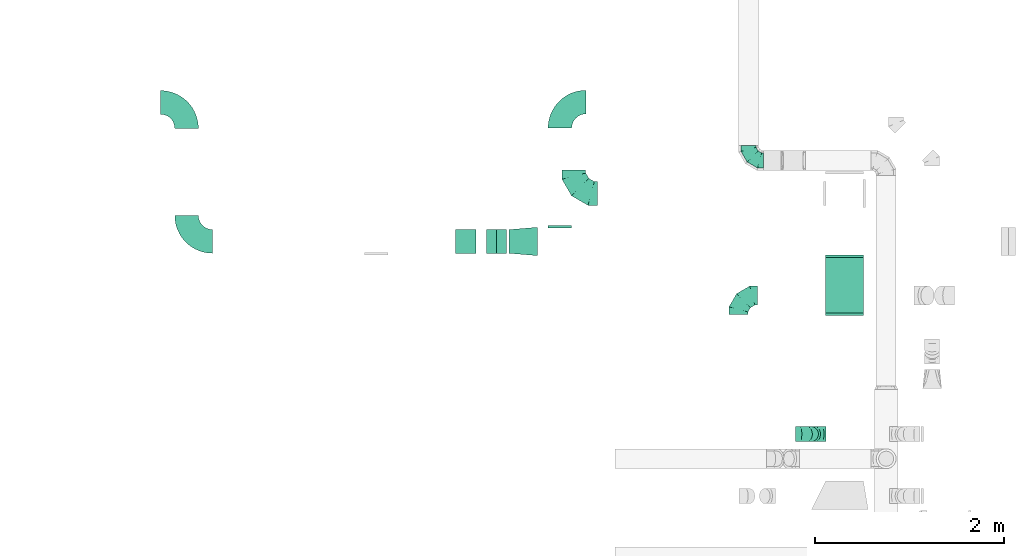
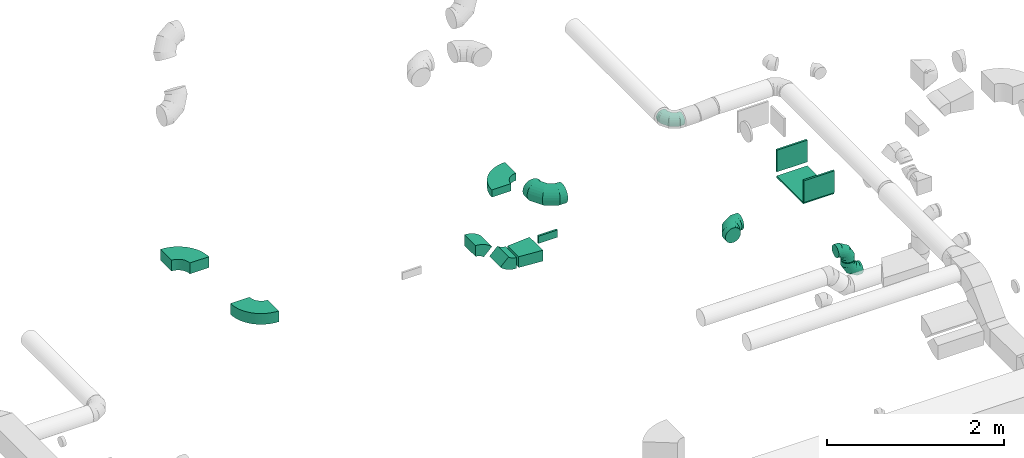
# One storey, part 35 of 62: 15 flow fittings.
"""IFC2X3 building model written with IfcOpenShell, lengths in millimetres."""

from ifc_helpers import new_model, entity, si_unit, converted_unit, derived_unit, direction, frame, frame_2d, origin, origin_2d_with_axis, place, context, subcontext, project, spatial, polyline, circle_curve, parameter, trimmed, segment, composite_curve, rectangle, outline, extrude, faceted_brep, source, transform, mapped, material, type_object, type_shapes, element, save


model = new_model("IFC2X3")

# Units and contexts
model_context = context("Model", 3, precision=0.01, world=origin(), true_north=direction((6.12303176911189e-17, 1.0)))
body_context = subcontext(model_context, "Body", "Model", "MODEL_VIEW")
ifc_project = project(units=[si_unit("LENGTHUNIT", "METRE", prefix="MILLI"), si_unit("AREAUNIT", "SQUARE_METRE"), si_unit("VOLUMEUNIT", "CUBIC_METRE"), converted_unit("PLANEANGLEUNIT", "DEGREE", entity("IfcRatioMeasure", 0.0174532925199433), si_unit("PLANEANGLEUNIT", "RADIAN"), dimensions=[0, 0, 0, 0, 0, 0, 0]), si_unit("MASSUNIT", "GRAM", prefix="KILO"), derived_unit("MASSDENSITYUNIT", [(si_unit("MASSUNIT", "GRAM", prefix="KILO"), 1), (si_unit("LENGTHUNIT", "METRE"), -3)]), derived_unit("MOMENTOFINERTIAUNIT", [(si_unit("LENGTHUNIT", "METRE"), 4)]), si_unit("TIMEUNIT", "SECOND"), si_unit("FREQUENCYUNIT", "HERTZ"), si_unit("THERMODYNAMICTEMPERATUREUNIT", "DEGREE_CELSIUS"), derived_unit("THERMALTRANSMITTANCEUNIT", [(si_unit("MASSUNIT", "GRAM", prefix="KILO"), 1), (si_unit("THERMODYNAMICTEMPERATUREUNIT", "KELVIN"), -1), (si_unit("TIMEUNIT", "SECOND"), -3)]), derived_unit("VOLUMETRICFLOWRATEUNIT", [(si_unit("LENGTHUNIT", "METRE"), 3), (si_unit("TIMEUNIT", "SECOND"), -1)]), derived_unit("MASSFLOWRATEUNIT", [(si_unit("MASSUNIT", "GRAM", prefix="KILO"), 1), (si_unit("TIMEUNIT", "SECOND"), -1)]), derived_unit("ROTATIONALFREQUENCYUNIT", [(si_unit("TIMEUNIT", "SECOND"), -1)]), si_unit("ELECTRICCURRENTUNIT", "AMPERE"), si_unit("ELECTRICVOLTAGEUNIT", "VOLT"), si_unit("POWERUNIT", "WATT"), si_unit("FORCEUNIT", "NEWTON", prefix="KILO"), si_unit("ILLUMINANCEUNIT", "LUX"), si_unit("LUMINOUSFLUXUNIT", "LUMEN"), si_unit("LUMINOUSINTENSITYUNIT", "CANDELA"), derived_unit("USERDEFINED", [(si_unit("MASSUNIT", "GRAM", prefix="KILO"), -1), (si_unit("LENGTHUNIT", "METRE"), -2), (si_unit("TIMEUNIT", "SECOND"), 3), (si_unit("LUMINOUSFLUXUNIT", "LUMEN"), 1)]), derived_unit("LINEARVELOCITYUNIT", [(si_unit("LENGTHUNIT", "METRE"), 1), (si_unit("TIMEUNIT", "SECOND"), -1)]), si_unit("PRESSUREUNIT", "PASCAL"), derived_unit("USERDEFINED", [(si_unit("LENGTHUNIT", "METRE"), -2), (si_unit("MASSUNIT", "GRAM", prefix="KILO"), 1), (si_unit("TIMEUNIT", "SECOND"), -2)]), derived_unit("LINEARFORCEUNIT", [(si_unit("MASSUNIT", "GRAM", prefix="KILO"), 1), (si_unit("LENGTHUNIT", "METRE"), 1), (si_unit("TIMEUNIT", "SECOND"), -2), (si_unit("LENGTHUNIT", "METRE"), -1)]), derived_unit("PLANARFORCEUNIT", [(si_unit("MASSUNIT", "GRAM", prefix="KILO"), 1), (si_unit("LENGTHUNIT", "METRE"), 1), (si_unit("TIMEUNIT", "SECOND"), -2), (si_unit("LENGTHUNIT", "METRE"), -2)])], contexts=[model_context])

# Site, building, storey
site_placement = place(None, origin())
site = spatial("IfcSite", under=ifc_project, at=site_placement, CompositionType="ELEMENT")
building_placement = place(site_placement, origin())
building = spatial("IfcBuilding", under=site, at=building_placement, CompositionType="ELEMENT")
storey_placement = place(building_placement, frame((0.0, 0.0, 24000.0)))
storey = spatial("IfcBuildingStorey", under=building, at=storey_placement, CompositionType="ELEMENT", Elevation=24000.0)

# Flow fittings
ifc_material = material()
duct_fitting_type_1 = type_object("IfcDuctFittingType", PredefinedType="NOTDEFINED", material=ifc_material)
shared_shape_1 = source(origin(), body_context, "Body", "SweptSolid", [
    extrude(rectangle(XDim=26.0960000000546, YDim=300.0, at=origin_2d_with_axis()), frame((6.95, 0.0, -200.0)), (0.0, 0.0, 1.0), 400.0),
])
type_shapes(duct_fitting_type_1, [shared_shape_1])
for number, where, z_axis, x_axis in (
    (1, (50316.44, 14444.03, 3450.0), (1.0, 0.0, 0.0), (0.0, 1.0, 0.0)),
    (2, (50316.44, 13844.03, 3400.0), (-1.0, 0.0, 0.0), (0.0, -1.0, 0.0)),
):
    element("IfcFlowFitting", number, at=place(storey_placement, frame(where, z_axis=z_axis, x_axis=x_axis)), inside=storey, type_object=duct_fitting_type_1, material=ifc_material, context=body_context, shape_type="MappedRepresentation", body=[
        mapped(shared_shape_1, transform((0.0, 0.0, 0.0), scale=1.0)),
    ])
duct_fitting_type_2 = type_object("IfcDuctFittingType", PredefinedType="NOTDEFINED", material=ifc_material)
shared_shape_2 = source(origin(), body_context, "Body", "SweptSolid", [
    extrude(rectangle(XDim=24.9999999999999, YDim=400.0, at=origin_2d_with_axis()), frame((12.5, 0.0, -300.0)), (0.0, 0.0, 1.0), 600.0),
])
type_shapes(duct_fitting_type_2, [shared_shape_2])
flow_fitting_1_placement = place(storey_placement, frame((50316.44, 14144.03, 3243.0), z_axis=(0.0, -1.0, 0.0), x_axis=(0.0, 0.0, -1.0)))
element("IfcFlowFitting", 3, at=flow_fitting_1_placement, inside=storey, type_object=duct_fitting_type_2, material=ifc_material, context=body_context, shape_type="MappedRepresentation", body=[
    mapped(shared_shape_2, transform((0.0, 0.0, 0.0), scale=1.0)),
])
duct_fitting_type_3 = type_object("IfcDuctFittingType", PredefinedType="NOTDEFINED", material=ifc_material)
shared_shape_3 = source(origin(), body_context, "Body", "SweptSolid", [
    extrude(rectangle(XDim=26.096000000009, YDim=250.0, at=origin_2d_with_axis()), frame((6.95, 0.0, -50.0)), (0.0, 0.0, 1.0), 100.0),
])
type_shapes(duct_fitting_type_3, [shared_shape_3])
flow_fitting_2_placement = place(storey_placement, frame((47308.77, 14756.21, 3200.0), z_axis=(0.0, 0.0, -1.0), x_axis=(0.0, 1.0, 0.0)))
element("IfcFlowFitting", 4, at=flow_fitting_2_placement, inside=storey, type_object=duct_fitting_type_3, material=ifc_material, context=body_context, shape_type="MappedRepresentation", body=[
    mapped(shared_shape_3, transform((0.0, 0.0, 0.0), scale=1.0)),
])
duct_fitting_type_4 = type_object("IfcDuctFittingType", PredefinedType="NOTDEFINED", material=ifc_material)
shared_shape_4 = source(origin(), body_context, "Body", "SweptSolid", [
    extrude(outline(polyline([(-139.1, -137.03), (161.94, -137.03), (137.03, 161.94), (-159.86, 112.11), (-139.1, -137.03)])), frame((150.0, 0.0, -75.0), z_axis=(0.0, 0.0, 1.0), x_axis=(0.996545758244879, -0.0830454798537418, 0.0)), (0.0, 0.0, 1.0), 150.0),
])
type_shapes(duct_fitting_type_4, [shared_shape_4])
flow_fitting_3_placement = place(storey_placement, frame((46771.44, 14606.21, 3200.0)))
element("IfcFlowFitting", 5, at=flow_fitting_3_placement, inside=storey, type_object=duct_fitting_type_4, material=ifc_material, context=body_context, shape_type="MappedRepresentation", body=[
    mapped(shared_shape_4, transform((0.0, 0.0, 0.0), scale=1.0)),
])
duct_fitting_type_5 = type_object("IfcDuctFittingType", PredefinedType="NOTDEFINED", material=ifc_material)
shared_shape_5 = source(origin(), body_context, "Body", "Brep", [
    faceted_brep([(-160.0, 0.0, -80.0), (-160.0, -20.71, -77.27), (-160.0, -40.0, -69.28), (-160.0, -56.57, -56.57), (-160.0, -69.28, -40.0), (-160.0, -77.27, -20.71), (-160.0, -80.0, 0.0), (-160.0, -77.27, 20.71), (-160.0, -69.28, 40.0), (-160.0, -56.57, 56.57), (-160.0, -40.0, 69.28), (-160.0, -20.71, 77.27), (-160.0, 0.0, 80.0), (-160.0, 20.71, 77.27), (-160.0, 40.0, 69.28), (-160.0, 56.57, 56.57), (-160.0, 69.28, 40.0), (-160.0, 77.27, 20.71), (-160.0, 80.0, 0.0), (-160.0, 77.27, -20.71), (-160.0, 69.28, -40.0), (-160.0, 56.57, -56.57), (-160.0, 40.0, -69.28), (-160.0, 20.71, -77.27), (-122.68, 20.71, 77.27), (-127.85, 40.0, 69.28), (-117.13, 0.0, 80.0), (-132.29, 56.57, 56.57), (-137.83, 77.27, 20.71), (-138.56, 80.0, 0.0), (-135.69, 69.28, 40.0), (-135.69, 69.28, -40.0), (-132.29, 56.57, -56.57), (-137.83, 77.27, -20.71), (-122.68, 20.71, -77.27), (-117.13, 0.0, -80.0), (-127.85, 40.0, -69.28), (-111.58, -20.71, -77.27), (-106.41, -40.0, -69.28), (-101.97, -56.57, -56.57), (-98.56, -69.28, -40.0), (-96.42, -77.27, -20.71), (-95.69, -80.0, 0.0), (-96.42, -77.27, 20.71), (-98.56, -69.28, 40.0), (-101.97, -56.57, 56.57), (-106.41, -40.0, 69.28), (-111.58, -20.71, 77.27), (-58.03, 58.03, 77.27), (-72.15, 72.15, 69.28), (-42.87, 42.87, 80.0), (-84.28, 84.28, 56.57), (-93.59, 93.59, 40.0), (-99.44, 99.44, 20.71), (-101.44, 101.44, 0.0), (-99.44, 99.44, -20.71), (-93.59, 93.59, -40.0), (-84.28, 84.28, -56.57), (-58.03, 58.03, -77.27), (-42.87, 42.87, -80.0), (-72.15, 72.15, -69.28), (-27.71, 27.71, -77.27), (-13.59, 13.59, -69.28), (-1.46, 1.46, -56.57), (7.85, -7.85, -40.0), (13.7, -13.7, -20.71), (15.69, -15.69, 0.0), (13.7, -13.7, 20.71), (7.85, -7.85, 40.0), (-1.46, 1.46, 56.57), (-13.59, 13.59, 69.28), (-27.71, 27.71, 77.27), (-20.71, 122.68, 77.27), (-40.0, 127.85, 69.28), (0.0, 117.13, 80.0), (-56.57, 132.29, 56.57), (-69.28, 135.69, 40.0), (-77.27, 137.83, 20.71), (-80.0, 138.56, 0.0), (-77.27, 137.83, -20.71), (-69.28, 135.69, -40.0), (-56.57, 132.29, -56.57), (-20.71, 122.68, -77.27), (0.0, 117.13, -80.0), (-40.0, 127.85, -69.28), (20.71, 111.58, -77.27), (40.0, 106.41, -69.28), (56.57, 101.97, -56.57), (69.28, 98.56, -40.0), (77.27, 96.42, -20.71), (80.0, 95.69, 0.0), (77.27, 96.42, 20.71), (69.28, 98.56, 40.0), (56.57, 101.97, 56.57), (40.0, 106.41, 69.28), (20.71, 111.58, 77.27), (-20.71, 160.0, -77.27), (-40.0, 160.0, -69.28), (-56.57, 160.0, -56.57), (-69.28, 160.0, -40.0), (-77.27, 160.0, -20.71), (-80.0, 160.0, 0.0), (-77.27, 160.0, 20.71), (-69.28, 160.0, 40.0), (-56.57, 160.0, 56.57), (-40.0, 160.0, 69.28), (-20.71, 160.0, 77.27), (0.0, 160.0, 80.0), (20.71, 160.0, 77.27), (40.0, 160.0, 69.28), (56.57, 160.0, 56.57), (69.28, 160.0, 40.0), (77.27, 160.0, 20.71), (80.0, 160.0, 0.0), (77.27, 160.0, -20.71), (69.28, 160.0, -40.0), (56.57, 160.0, -56.57), (40.0, 160.0, -69.28), (20.71, 160.0, -77.27), (0.0, 160.0, -80.0)], [[[0, 1, 2, 3, 4, 5, 6, 7, 8, 9, 10, 11, 12, 13, 14, 15, 16, 17, 18, 19, 20, 21, 22, 23]], [[24, 25, 14, 13]], [[26, 24, 13, 12]], [[14, 25, 27, 15]], [[28, 29, 18, 17]], [[30, 28, 17, 16]], [[15, 27, 30, 16]], [[20, 31, 32, 21]], [[33, 31, 20, 19]], [[18, 29, 33, 19]], [[34, 35, 0, 23]], [[36, 34, 23, 22]], [[32, 36, 22, 21]], [[1, 0, 35, 37]], [[2, 1, 37, 38]], [[3, 2, 38, 39]], [[5, 4, 40, 41]], [[6, 5, 41, 42]], [[39, 40, 4, 3]], [[6, 42, 43, 7]], [[7, 43, 44, 8]], [[8, 44, 45, 9]], [[9, 45, 46, 10]], [[10, 46, 47, 11]], [[26, 12, 11, 47]], [[48, 49, 25, 24]], [[50, 48, 24, 26]], [[27, 25, 49, 51]], [[52, 53, 28, 30]], [[51, 52, 30, 27]], [[29, 28, 53, 54]], [[55, 56, 31, 33]], [[54, 55, 33, 29]], [[32, 31, 56, 57]], [[58, 59, 35, 34]], [[60, 58, 34, 36]], [[57, 60, 36, 32]], [[37, 35, 59, 61]], [[38, 37, 61, 62]], [[39, 38, 62, 63]], [[41, 40, 64, 65]], [[42, 41, 65, 66]], [[63, 64, 40, 39]], [[43, 42, 66, 67]], [[44, 43, 67, 68]], [[68, 69, 45, 44]], [[46, 45, 69, 70]], [[47, 46, 70, 71]], [[26, 47, 71, 50]], [[72, 73, 49, 48]], [[74, 72, 48, 50]], [[51, 49, 73, 75]], [[76, 77, 53, 52]], [[75, 76, 52, 51]], [[54, 53, 77, 78]], [[79, 80, 56, 55]], [[78, 79, 55, 54]], [[57, 56, 80, 81]], [[82, 83, 59, 58]], [[84, 82, 58, 60]], [[81, 84, 60, 57]], [[61, 59, 83, 85]], [[62, 61, 85, 86]], [[63, 62, 86, 87]], [[65, 64, 88, 89]], [[66, 65, 89, 90]], [[87, 88, 64, 63]], [[67, 66, 90, 91]], [[68, 67, 91, 92]], [[92, 93, 69, 68]], [[70, 69, 93, 94]], [[71, 70, 94, 95]], [[50, 71, 95, 74]], [[96, 97, 98, 99, 100, 101, 102, 103, 104, 105, 106, 107, 108, 109, 110, 111, 112, 113, 114, 115, 116, 117, 118, 119]], [[72, 74, 107, 106]], [[73, 72, 106, 105]], [[75, 73, 105, 104]], [[77, 76, 103, 102]], [[78, 77, 102, 101]], [[75, 104, 103, 76]], [[78, 101, 100, 79]], [[79, 100, 99, 80]], [[80, 99, 98, 81]], [[84, 97, 96, 82]], [[82, 96, 119, 83]], [[84, 81, 98, 97]], [[118, 117, 86, 85]], [[119, 118, 85, 83]], [[116, 87, 86, 117]], [[88, 115, 114, 89]], [[89, 114, 113, 90]], [[115, 88, 87, 116]], [[112, 111, 92, 91]], [[113, 112, 91, 90]], [[111, 110, 93, 92]], [[95, 94, 109, 108]], [[74, 95, 108, 107]], [[110, 109, 94, 93]]]),
])
type_shapes(duct_fitting_type_5, [shared_shape_5])
for number, where, z_axis, x_axis in (
    (6, (49302.56, 15461.83, 3650.0), (0.0, 0.0, 1.0), (0.0, -1.0, 0.0)),
    (7, (49961.09, 12570.09, 3120.0), (0.0, 1.0, 0.0), (-1.0, 0.0, 0.0)),
    (8, (49961.09, 12570.09, 3450.0), (0.0, -1.0, 0.0), (0.0, 0.0, 1.0)),
):
    element("IfcFlowFitting", number, at=place(storey_placement, frame(where, z_axis=z_axis, x_axis=x_axis)), inside=storey, type_object=duct_fitting_type_5, material=ifc_material, context=body_context, shape_type="MappedRepresentation", body=[
        mapped(shared_shape_5, transform((0.0, 0.0, 0.0), scale=1.0)),
    ])
duct_fitting_type_6 = type_object("IfcDuctFittingType", PredefinedType="NOTDEFINED", material=ifc_material)
shared_shape_6 = source(origin(), body_context, "Body", "Brep", [
    faceted_brep([(-250.0, 0.0, -125.0), (-250.0, -32.35, -120.74), (-250.0, -62.5, -108.25), (-250.0, -88.39, -88.39), (-250.0, -108.25, -62.5), (-250.0, -120.74, -32.35), (-250.0, -125.0, 0.0), (-250.0, -120.74, 32.35), (-250.0, -108.25, 62.5), (-250.0, -88.39, 88.39), (-250.0, -62.5, 108.25), (-250.0, -32.35, 120.74), (-250.0, 0.0, 125.0), (-250.0, 32.35, 120.74), (-250.0, 62.5, 108.25), (-250.0, 88.39, 88.39), (-250.0, 108.25, 62.5), (-250.0, 120.74, 32.35), (-250.0, 125.0, 0.0), (-250.0, 120.74, -32.35), (-250.0, 108.25, -62.5), (-250.0, 88.39, -88.39), (-250.0, 62.5, -108.25), (-250.0, 32.35, -120.74), (-191.68, 32.35, 120.74), (-199.76, 62.5, 108.25), (-183.01, 0.0, 125.0), (-206.7, 88.39, 88.39), (-215.37, 120.74, 32.35), (-216.51, 125.0, 0.0), (-212.02, 108.25, 62.5), (-212.02, 108.25, -62.5), (-206.7, 88.39, -88.39), (-215.37, 120.74, -32.35), (-191.68, 32.35, -120.74), (-183.01, 0.0, -125.0), (-199.76, 62.5, -108.25), (-174.34, -32.35, -120.74), (-166.27, -62.5, -108.25), (-159.33, -88.39, -88.39), (-154.01, -108.25, -62.5), (-150.66, -120.74, -32.35), (-149.52, -125.0, 0.0), (-150.66, -120.74, 32.35), (-154.01, -108.25, 62.5), (-159.33, -88.39, 88.39), (-166.27, -62.5, 108.25), (-174.34, -32.35, 120.74), (-90.67, 90.67, 120.74), (-112.74, 112.74, 108.25), (-66.99, 66.99, 125.0), (-131.69, 131.69, 88.39), (-146.23, 146.23, 62.5), (-155.38, 155.38, 32.35), (-158.49, 158.49, 0.0), (-155.38, 155.38, -32.35), (-146.23, 146.23, -62.5), (-131.69, 131.69, -88.39), (-90.67, 90.67, -120.74), (-66.99, 66.99, -125.0), (-112.74, 112.74, -108.25), (-43.3, 43.3, -120.74), (-21.23, 21.23, -108.25), (-2.28, 2.28, -88.39), (12.26, -12.26, -62.5), (21.4, -21.4, -32.35), (24.52, -24.52, 0.0), (21.4, -21.4, 32.35), (12.26, -12.26, 62.5), (-2.28, 2.28, 88.39), (-21.23, 21.23, 108.25), (-43.3, 43.3, 120.74), (-32.35, 191.68, 120.74), (-62.5, 199.76, 108.25), (0.0, 183.01, 125.0), (-88.39, 206.7, 88.39), (-108.25, 212.02, 62.5), (-120.74, 215.37, 32.35), (-125.0, 216.51, 0.0), (-120.74, 215.37, -32.35), (-108.25, 212.02, -62.5), (-88.39, 206.7, -88.39), (-32.35, 191.68, -120.74), (0.0, 183.01, -125.0), (-62.5, 199.76, -108.25), (32.35, 174.34, -120.74), (62.5, 166.27, -108.25), (88.39, 159.33, -88.39), (108.25, 154.01, -62.5), (120.74, 150.66, -32.35), (125.0, 149.52, 0.0), (120.74, 150.66, 32.35), (108.25, 154.01, 62.5), (88.39, 159.33, 88.39), (62.5, 166.27, 108.25), (32.35, 174.34, 120.74), (-32.35, 250.0, -120.74), (-62.5, 250.0, -108.25), (-88.39, 250.0, -88.39), (-108.25, 250.0, -62.5), (-120.74, 250.0, -32.35), (-125.0, 250.0, 0.0), (-120.74, 250.0, 32.35), (-108.25, 250.0, 62.5), (-88.39, 250.0, 88.39), (-62.5, 250.0, 108.25), (-32.35, 250.0, 120.74), (0.0, 250.0, 125.0), (32.35, 250.0, 120.74), (62.5, 250.0, 108.25), (88.39, 250.0, 88.39), (108.25, 250.0, 62.5), (120.74, 250.0, 32.35), (125.0, 250.0, 0.0), (120.74, 250.0, -32.35), (108.25, 250.0, -62.5), (88.39, 250.0, -88.39), (62.5, 250.0, -108.25), (32.35, 250.0, -120.74), (0.0, 250.0, -125.0)], [[[0, 1, 2, 3, 4, 5, 6, 7, 8, 9, 10, 11, 12, 13, 14, 15, 16, 17, 18, 19, 20, 21, 22, 23]], [[24, 25, 14, 13]], [[26, 24, 13, 12]], [[14, 25, 27, 15]], [[28, 29, 18, 17]], [[30, 28, 17, 16]], [[15, 27, 30, 16]], [[20, 31, 32, 21]], [[33, 31, 20, 19]], [[18, 29, 33, 19]], [[34, 35, 0, 23]], [[36, 34, 23, 22]], [[21, 32, 36, 22]], [[1, 0, 35, 37]], [[2, 1, 37, 38]], [[38, 39, 3, 2]], [[5, 4, 40, 41]], [[6, 5, 41, 42]], [[39, 40, 4, 3]], [[6, 42, 43, 7]], [[7, 43, 44, 8]], [[8, 44, 45, 9]], [[9, 45, 46, 10]], [[10, 46, 47, 11]], [[26, 12, 11, 47]], [[48, 49, 25, 24]], [[50, 48, 24, 26]], [[27, 25, 49, 51]], [[52, 53, 28, 30]], [[51, 52, 30, 27]], [[29, 28, 53, 54]], [[55, 56, 31, 33]], [[54, 55, 33, 29]], [[32, 31, 56, 57]], [[58, 59, 35, 34]], [[60, 58, 34, 36]], [[57, 60, 36, 32]], [[37, 35, 59, 61]], [[38, 37, 61, 62]], [[39, 38, 62, 63]], [[41, 40, 64, 65]], [[42, 41, 65, 66]], [[63, 64, 40, 39]], [[43, 42, 66, 67]], [[44, 43, 67, 68]], [[68, 69, 45, 44]], [[46, 45, 69, 70]], [[47, 46, 70, 71]], [[26, 47, 71, 50]], [[72, 73, 49, 48]], [[74, 72, 48, 50]], [[51, 49, 73, 75]], [[76, 77, 53, 52]], [[75, 76, 52, 51]], [[54, 53, 77, 78]], [[79, 80, 56, 55]], [[78, 79, 55, 54]], [[57, 56, 80, 81]], [[82, 83, 59, 58]], [[84, 82, 58, 60]], [[81, 84, 60, 57]], [[61, 59, 83, 85]], [[62, 61, 85, 86]], [[63, 62, 86, 87]], [[65, 64, 88, 89]], [[66, 65, 89, 90]], [[87, 88, 64, 63]], [[67, 66, 90, 91]], [[68, 67, 91, 92]], [[92, 93, 69, 68]], [[70, 69, 93, 94]], [[71, 70, 94, 95]], [[50, 71, 95, 74]], [[96, 97, 98, 99, 100, 101, 102, 103, 104, 105, 106, 107, 108, 109, 110, 111, 112, 113, 114, 115, 116, 117, 118, 119]], [[72, 74, 107, 106]], [[73, 72, 106, 105]], [[75, 73, 105, 104]], [[77, 76, 103, 102]], [[78, 77, 102, 101]], [[75, 104, 103, 76]], [[78, 101, 100, 79]], [[79, 100, 99, 80]], [[80, 99, 98, 81]], [[84, 97, 96, 82]], [[82, 96, 119, 83]], [[84, 81, 98, 97]], [[83, 119, 118, 85]], [[85, 118, 117, 86]], [[116, 87, 86, 117]], [[88, 115, 114, 89]], [[89, 114, 113, 90]], [[115, 88, 87, 116]], [[91, 90, 113, 112]], [[92, 91, 112, 111]], [[111, 110, 93, 92]], [[95, 94, 109, 108]], [[74, 95, 108, 107]], [[110, 109, 94, 93]]]),
])
type_shapes(duct_fitting_type_6, [shared_shape_6])
flow_fitting_4_placement = place(storey_placement, frame((47456.43, 15113.09, 3450.0), z_axis=(0.0, 0.0, 1.0), x_axis=(0.0, -1.0, 0.0)))
element("IfcFlowFitting", 9, at=flow_fitting_4_placement, inside=storey, type_object=duct_fitting_type_6, material=ifc_material, context=body_context, shape_type="MappedRepresentation", body=[
    mapped(shared_shape_6, transform((0.0, 0.0, 0.0), scale=1.0)),
])
duct_fitting_type_7 = type_object("IfcDuctFittingType", PredefinedType="NOTDEFINED", material=ifc_material)
shared_shape_7 = source(origin(), body_context, "Body", "Brep", [
    faceted_brep([(-200.0, 0.0, -100.0), (-200.0, -25.88, -96.59), (-200.0, -50.0, -86.6), (-200.0, -70.71, -70.71), (-200.0, -86.6, -50.0), (-200.0, -96.59, -25.88), (-200.0, -100.0, 0.0), (-200.0, -96.59, 25.88), (-200.0, -86.6, 50.0), (-200.0, -70.71, 70.71), (-200.0, -50.0, 86.6), (-200.0, -25.88, 96.59), (-200.0, 0.0, 100.0), (-200.0, 25.88, 96.59), (-200.0, 50.0, 86.6), (-200.0, 70.71, 70.71), (-200.0, 86.6, 50.0), (-200.0, 96.59, 25.88), (-200.0, 100.0, 0.0), (-200.0, 96.59, -25.88), (-200.0, 86.6, -50.0), (-200.0, 70.71, -70.71), (-200.0, 50.0, -86.6), (-200.0, 25.88, -96.59), (-153.35, 25.88, 96.59), (-159.81, 50.0, 86.6), (-146.41, 0.0, 100.0), (-165.36, 70.71, 70.71), (-172.29, 96.59, 25.88), (-173.21, 100.0, 0.0), (-169.62, 86.6, 50.0), (-169.62, 86.6, -50.0), (-165.36, 70.71, -70.71), (-172.29, 96.59, -25.88), (-153.35, 25.88, -96.59), (-146.41, 0.0, -100.0), (-159.81, 50.0, -86.6), (-139.48, -25.88, -96.59), (-133.01, -50.0, -86.6), (-127.46, -70.71, -70.71), (-123.21, -86.6, -50.0), (-120.53, -96.59, -25.88), (-119.62, -100.0, 0.0), (-120.53, -96.59, 25.88), (-123.21, -86.6, 50.0), (-127.46, -70.71, 70.71), (-133.01, -50.0, 86.6), (-139.48, -25.88, 96.59), (-72.54, 72.54, 96.59), (-90.19, 90.19, 86.6), (-53.59, 53.59, 100.0), (-105.35, 105.35, 70.71), (-116.99, 116.99, 50.0), (-124.3, 124.3, 25.88), (-126.79, 126.79, 0.0), (-124.3, 124.3, -25.88), (-116.99, 116.99, -50.0), (-105.35, 105.35, -70.71), (-72.54, 72.54, -96.59), (-53.59, 53.59, -100.0), (-90.19, 90.19, -86.6), (-34.64, 34.64, -96.59), (-16.99, 16.99, -86.6), (-1.83, 1.83, -70.71), (9.81, -9.81, -50.0), (17.12, -17.12, -25.88), (19.62, -19.62, 0.0), (17.12, -17.12, 25.88), (9.81, -9.81, 50.0), (-1.83, 1.83, 70.71), (-16.99, 16.99, 86.6), (-34.64, 34.64, 96.59), (-25.88, 153.35, 96.59), (-50.0, 159.81, 86.6), (0.0, 146.41, 100.0), (-70.71, 165.36, 70.71), (-86.6, 169.62, 50.0), (-96.59, 172.29, 25.88), (-100.0, 173.21, 0.0), (-96.59, 172.29, -25.88), (-86.6, 169.62, -50.0), (-70.71, 165.36, -70.71), (-25.88, 153.35, -96.59), (0.0, 146.41, -100.0), (-50.0, 159.81, -86.6), (25.88, 139.48, -96.59), (50.0, 133.01, -86.6), (70.71, 127.46, -70.71), (86.6, 123.21, -50.0), (96.59, 120.53, -25.88), (100.0, 119.62, 0.0), (96.59, 120.53, 25.88), (86.6, 123.21, 50.0), (70.71, 127.46, 70.71), (50.0, 133.01, 86.6), (25.88, 139.48, 96.59), (-25.88, 200.0, -96.59), (-50.0, 200.0, -86.6), (-70.71, 200.0, -70.71), (-86.6, 200.0, -50.0), (-96.59, 200.0, -25.88), (-100.0, 200.0, 0.0), (-96.59, 200.0, 25.88), (-86.6, 200.0, 50.0), (-70.71, 200.0, 70.71), (-50.0, 200.0, 86.6), (-25.88, 200.0, 96.59), (0.0, 200.0, 100.0), (25.88, 200.0, 96.59), (50.0, 200.0, 86.6), (70.71, 200.0, 70.71), (86.6, 200.0, 50.0), (96.59, 200.0, 25.88), (100.0, 200.0, 0.0), (96.59, 200.0, -25.88), (86.6, 200.0, -50.0), (70.71, 200.0, -70.71), (50.0, 200.0, -86.6), (25.88, 200.0, -96.59), (0.0, 200.0, -100.0)], [[[0, 1, 2, 3, 4, 5, 6, 7, 8, 9, 10, 11, 12, 13, 14, 15, 16, 17, 18, 19, 20, 21, 22, 23]], [[24, 25, 14, 13]], [[26, 24, 13, 12]], [[14, 25, 27, 15]], [[28, 29, 18, 17]], [[30, 28, 17, 16]], [[15, 27, 30, 16]], [[20, 31, 32, 21]], [[33, 31, 20, 19]], [[18, 29, 33, 19]], [[34, 35, 0, 23]], [[36, 34, 23, 22]], [[32, 36, 22, 21]], [[1, 0, 35, 37]], [[2, 1, 37, 38]], [[38, 39, 3, 2]], [[5, 4, 40, 41]], [[6, 5, 41, 42]], [[39, 40, 4, 3]], [[6, 42, 43, 7]], [[7, 43, 44, 8]], [[8, 44, 45, 9]], [[9, 45, 46, 10]], [[10, 46, 47, 11]], [[26, 12, 11, 47]], [[48, 49, 25, 24]], [[50, 48, 24, 26]], [[27, 25, 49, 51]], [[52, 53, 28, 30]], [[51, 52, 30, 27]], [[29, 28, 53, 54]], [[55, 56, 31, 33]], [[54, 55, 33, 29]], [[32, 31, 56, 57]], [[58, 59, 35, 34]], [[60, 58, 34, 36]], [[57, 60, 36, 32]], [[37, 35, 59, 61]], [[38, 37, 61, 62]], [[39, 38, 62, 63]], [[41, 40, 64, 65]], [[42, 41, 65, 66]], [[63, 64, 40, 39]], [[43, 42, 66, 67]], [[44, 43, 67, 68]], [[68, 69, 45, 44]], [[46, 45, 69, 70]], [[47, 46, 70, 71]], [[26, 47, 71, 50]], [[72, 73, 49, 48]], [[74, 72, 48, 50]], [[51, 49, 73, 75]], [[76, 77, 53, 52]], [[75, 76, 52, 51]], [[54, 53, 77, 78]], [[79, 80, 56, 55]], [[78, 79, 55, 54]], [[57, 56, 80, 81]], [[82, 83, 59, 58]], [[84, 82, 58, 60]], [[81, 84, 60, 57]], [[61, 59, 83, 85]], [[62, 61, 85, 86]], [[63, 62, 86, 87]], [[65, 64, 88, 89]], [[66, 65, 89, 90]], [[87, 88, 64, 63]], [[67, 66, 90, 91]], [[68, 67, 91, 92]], [[92, 93, 69, 68]], [[70, 69, 93, 94]], [[71, 70, 94, 95]], [[50, 71, 95, 74]], [[96, 97, 98, 99, 100, 101, 102, 103, 104, 105, 106, 107, 108, 109, 110, 111, 112, 113, 114, 115, 116, 117, 118, 119]], [[72, 74, 107, 106]], [[73, 72, 106, 105]], [[75, 73, 105, 104]], [[102, 101, 78, 77]], [[103, 102, 77, 76]], [[75, 104, 103, 76]], [[78, 101, 100, 79]], [[79, 100, 99, 80]], [[80, 99, 98, 81]], [[84, 97, 96, 82]], [[82, 96, 119, 83]], [[84, 81, 98, 97]], [[118, 117, 86, 85]], [[119, 118, 85, 83]], [[116, 87, 86, 117]], [[88, 115, 114, 89]], [[89, 114, 113, 90]], [[115, 88, 87, 116]], [[91, 90, 113, 112]], [[92, 91, 112, 111]], [[111, 110, 93, 92]], [[95, 94, 109, 108]], [[74, 95, 108, 107]], [[110, 109, 94, 93]]]),
])
type_shapes(duct_fitting_type_7, [shared_shape_7])
flow_fitting_5_placement = place(storey_placement, frame((49195.82, 14034.27, 3114.71), z_axis=(0.0, 0.0, 1.0), x_axis=(-1.0, 0.0, 0.0)))
element("IfcFlowFitting", 10, at=flow_fitting_5_placement, inside=storey, type_object=duct_fitting_type_7, material=ifc_material, context=body_context, shape_type="MappedRepresentation", body=[
    mapped(shared_shape_7, transform((0.0, 0.0, 0.0), scale=1.0)),
])
duct_fitting_type_8 = type_object("IfcDuctFittingType", PredefinedType="NOTDEFINED", material=ifc_material)
shared_shape_8 = source(origin(), body_context, "Body", "SweptSolid", [
    extrude(outline(composite_curve([segment(polyline([(-262.5, -137.5), (-12.5, -137.5)]), True, "CONTINUOUS"), segment(trimmed(circle_curve(frame_2d((137.5, -137.5), x_axis=(0.0, 1.0)), 150.0), [parameter(0.0)], [parameter(90.0)], True, "PARAMETER"), False, "CONTINUOUS"), segment(polyline([(137.5, 12.5), (137.5, 262.5)]), True, "CONTINUOUS"), segment(trimmed(circle_curve(frame_2d((137.5, -137.5), x_axis=(0.0, 1.0)), 400.0), [parameter(0.0)], [parameter(90.0)], True, "PARAMETER"), True, "CONTINUOUS")], self_intersect=False)), frame((-137.5, 137.5, -50.0), z_axis=(0.0, 0.0, 1.0), x_axis=(-1.0, 0.0, 0.0)), (0.0, 0.0, 1.0), 100.0),
])
type_shapes(duct_fitting_type_8, [shared_shape_8])
flow_fitting_6_placement = place(storey_placement, frame((47308.77, 16078.71, 3200.0), z_axis=(0.0, 0.0, 1.0), x_axis=(-1.0, 0.0, 0.0)))
element("IfcFlowFitting", 11, at=flow_fitting_6_placement, inside=storey, type_object=duct_fitting_type_8, material=ifc_material, context=body_context, shape_type="MappedRepresentation", body=[
    mapped(shared_shape_8, transform((0.0, 0.0, 0.0), scale=1.0)),
])
duct_fitting_type_9 = type_object("IfcDuctFittingType", PredefinedType="NOTDEFINED", material=ifc_material)
shared_shape_9 = source(origin(), body_context, "Body", "SweptSolid", [
    extrude(outline(composite_curve([segment(polyline([(-262.5, -137.5), (-12.5, -137.5)]), True, "CONTINUOUS"), segment(trimmed(circle_curve(frame_2d((137.5, -137.5), x_axis=(0.0, 1.0)), 150.0), [parameter(0.0)], [parameter(90.0000000000001)], True, "PARAMETER"), False, "CONTINUOUS"), segment(polyline([(137.5, 12.5), (137.5, 262.5)]), True, "CONTINUOUS"), segment(trimmed(circle_curve(frame_2d((137.5, -137.5), x_axis=(0.0, 1.0)), 400.0), [parameter(0.0)], [parameter(90.0000000000001)], True, "PARAMETER"), True, "CONTINUOUS")], self_intersect=False)), frame((-137.5, 137.5, -75.0), z_axis=(0.0, 0.0, 1.0), x_axis=(-1.0, 0.0, 0.0)), (0.0, 0.0, 1.0), 150.0),
])
type_shapes(duct_fitting_type_9, [shared_shape_9])
for number, where, z_axis, x_axis in (
    (12, (43363.94, 14606.21, 3550.0), (0.0, 0.0, 1.0), (0.0, -1.0, 0.0)),
    (13, (43363.94, 16075.55, 3550.0), (0.0, 0.0, 1.0), (0.0, 1.0, 0.0)),
):
    element("IfcFlowFitting", number, at=place(storey_placement, frame(where, z_axis=z_axis, x_axis=x_axis)), inside=storey, type_object=duct_fitting_type_9, material=ifc_material, context=body_context, shape_type="MappedRepresentation", body=[
        mapped(shared_shape_9, transform((0.0, 0.0, 0.0), scale=1.0)),
    ])
duct_fitting_type_10 = type_object("IfcDuctFittingType", PredefinedType="NOTDEFINED", material=ifc_material)
shared_shape_10 = source(origin(), body_context, "Body", "SweptSolid", [
    extrude(outline(composite_curve([segment(polyline([(-107.95, -79.55), (42.05, -79.55)]), True, "CONTINUOUS"), segment(trimmed(circle_curve(frame_2d((192.05, -79.55), x_axis=(-0.707106781186546, 0.707106781186546)), 150.0), [parameter(0.0)], [parameter(45.0)], True, "PARAMETER"), False, "CONTINUOUS"), segment(polyline([(85.98, 26.52), (-20.08, 132.58)]), True, "CONTINUOUS"), segment(trimmed(circle_curve(frame_2d((192.05, -79.55), x_axis=(-0.707106781186546, 0.707106781186546)), 300.0), [parameter(0.0)], [parameter(45.0)], True, "PARAMETER"), True, "CONTINUOUS")], self_intersect=False)), frame((-13.65, 32.95, -125.0), z_axis=(0.0, 0.0, 1.0), x_axis=(-0.707106781186547, 0.707106781186548, 0.0)), (0.0, 0.0, 1.0), 250.0),
])
type_shapes(duct_fitting_type_10, [shared_shape_10])
for number, where, z_axis, x_axis in (
    (14, (46651.44, 14606.21, 3200.0), (0.0, 1.0, 0.0), (-1.0, 0.0, 0.0)),
    (15, (46301.44, 14606.21, 3550.0), (0.0, -1.0, 0.0), (-0.707106781186498, 0.0, 0.707106781186597)),
):
    element("IfcFlowFitting", number, at=place(storey_placement, frame(where, z_axis=z_axis, x_axis=x_axis)), inside=storey, type_object=duct_fitting_type_10, material=ifc_material, context=body_context, shape_type="MappedRepresentation", body=[
        mapped(shared_shape_10, transform((0.0, 0.0, 0.0), scale=1.0)),
    ])

save(model, "model.ifc")
